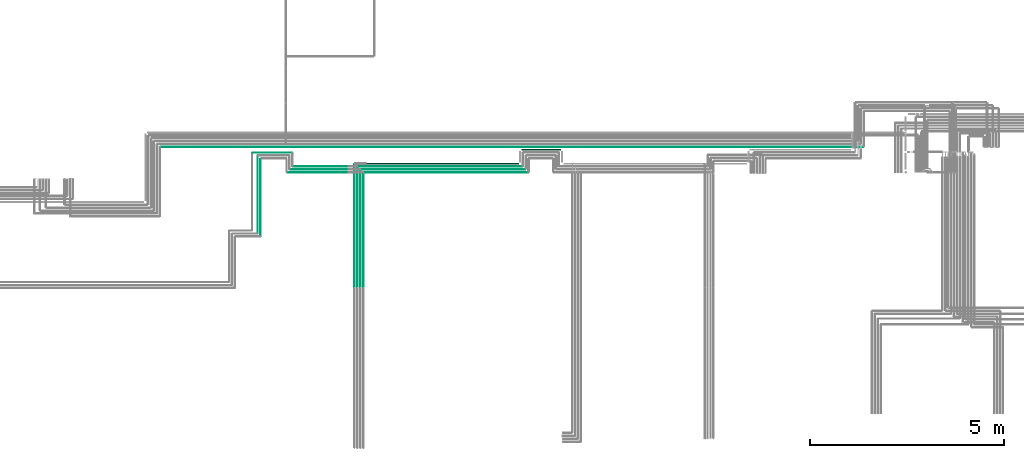
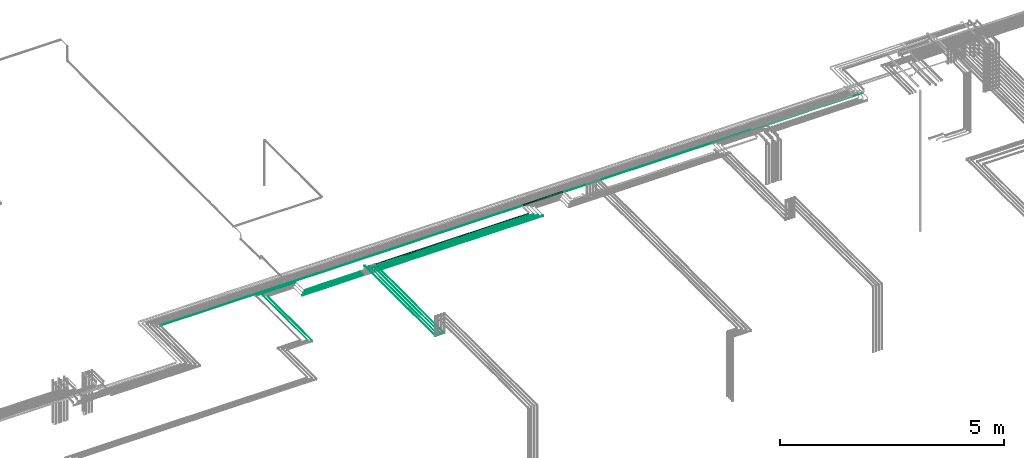
# One storey, part 11 of 65: 16 flow segments.
"""IFC2X3 building model written with IfcOpenShell, lengths in millimetres."""

from ifc_helpers import new_model, entity, si_unit, converted_unit, derived_unit, direction, frame, frame_2d, origin, origin_2d_with_axis, place, context, subcontext, project, spatial, circle, extrude, type_object, element, save


model = new_model("IFC2X3")

# Units and contexts
model_context = context("Model", 3, precision=0.01, world=origin(), true_north=direction((6.12303176911189e-17, 1.0)))
body_context = subcontext(model_context, "Body", "Model", "MODEL_VIEW")
ifc_project = project(units=[si_unit("LENGTHUNIT", "METRE", prefix="MILLI"), si_unit("AREAUNIT", "SQUARE_METRE"), si_unit("VOLUMEUNIT", "CUBIC_METRE"), converted_unit("PLANEANGLEUNIT", "DEGREE", entity("IfcRatioMeasure", 0.0174532925199433), si_unit("PLANEANGLEUNIT", "RADIAN"), dimensions=[0, 0, 0, 0, 0, 0, 0]), si_unit("MASSUNIT", "GRAM", prefix="KILO"), derived_unit("MASSDENSITYUNIT", [(si_unit("MASSUNIT", "GRAM", prefix="KILO"), 1), (si_unit("LENGTHUNIT", "METRE"), -3)]), derived_unit("MOMENTOFINERTIAUNIT", [(si_unit("LENGTHUNIT", "METRE"), 4)]), si_unit("TIMEUNIT", "SECOND"), si_unit("FREQUENCYUNIT", "HERTZ"), si_unit("THERMODYNAMICTEMPERATUREUNIT", "DEGREE_CELSIUS"), derived_unit("THERMALTRANSMITTANCEUNIT", [(si_unit("MASSUNIT", "GRAM", prefix="KILO"), 1), (si_unit("THERMODYNAMICTEMPERATUREUNIT", "KELVIN"), -1), (si_unit("TIMEUNIT", "SECOND"), -3)]), derived_unit("VOLUMETRICFLOWRATEUNIT", [(si_unit("LENGTHUNIT", "METRE"), 3), (si_unit("TIMEUNIT", "SECOND"), -1)]), derived_unit("MASSFLOWRATEUNIT", [(si_unit("MASSUNIT", "GRAM", prefix="KILO"), 1), (si_unit("TIMEUNIT", "SECOND"), -1)]), derived_unit("ROTATIONALFREQUENCYUNIT", [(si_unit("TIMEUNIT", "SECOND"), -1)]), si_unit("ELECTRICCURRENTUNIT", "AMPERE"), si_unit("ELECTRICVOLTAGEUNIT", "VOLT"), si_unit("POWERUNIT", "WATT"), si_unit("FORCEUNIT", "NEWTON", prefix="KILO"), si_unit("ILLUMINANCEUNIT", "LUX"), si_unit("LUMINOUSFLUXUNIT", "LUMEN"), si_unit("LUMINOUSINTENSITYUNIT", "CANDELA"), derived_unit("USERDEFINED", [(si_unit("MASSUNIT", "GRAM", prefix="KILO"), -1), (si_unit("LENGTHUNIT", "METRE"), -2), (si_unit("TIMEUNIT", "SECOND"), 3), (si_unit("LUMINOUSFLUXUNIT", "LUMEN"), 1)]), derived_unit("LINEARVELOCITYUNIT", [(si_unit("LENGTHUNIT", "METRE"), 1), (si_unit("TIMEUNIT", "SECOND"), -1)]), si_unit("PRESSUREUNIT", "PASCAL"), derived_unit("USERDEFINED", [(si_unit("LENGTHUNIT", "METRE"), -2), (si_unit("MASSUNIT", "GRAM", prefix="KILO"), 1), (si_unit("TIMEUNIT", "SECOND"), -2)]), derived_unit("LINEARFORCEUNIT", [(si_unit("MASSUNIT", "GRAM", prefix="KILO"), 1), (si_unit("LENGTHUNIT", "METRE"), 1), (si_unit("TIMEUNIT", "SECOND"), -2), (si_unit("LENGTHUNIT", "METRE"), -1)]), derived_unit("PLANARFORCEUNIT", [(si_unit("MASSUNIT", "GRAM", prefix="KILO"), 1), (si_unit("LENGTHUNIT", "METRE"), 1), (si_unit("TIMEUNIT", "SECOND"), -2), (si_unit("LENGTHUNIT", "METRE"), -2)])], contexts=[model_context])

# Site, building, storey
site_placement = place(None, frame((0.0, -0.00077364408347762, 0.0)))
site = spatial("IfcSite", under=ifc_project, at=site_placement, CompositionType="ELEMENT")
building_placement = place(site_placement, origin())
building = spatial("IfcBuilding", under=site, at=building_placement, CompositionType="ELEMENT")
storey_placement = place(building_placement, frame((0.0, 0.0, 19800.0)))
storey = spatial("IfcBuildingStorey", under=building, at=storey_placement, CompositionType="ELEMENT", Elevation=19800.0)

# Flow segments
pipe_segment_type = type_object("IfcPipeSegmentType", PredefinedType="NOTDEFINED")
flow_segment_1_placement = place(storey_placement, frame((55175.7164041243, 8230.90493375775, 2530.90472776409)))
element("IfcFlowSegment", 1, at=flow_segment_1_placement, inside=storey, type_object=pipe_segment_type, context=body_context, shape_type="SweptSolid", body=[
    extrude(circle(Radius=17.5, at=frame_2d((1.08286712929839e-12, 0.0), x_axis=(1.0, 0.0))), frame((0.0, 19.0952722359173, 19.0952722359163), z_axis=(1.0, 0.0, 0.0), x_axis=(0.0, 1.0, 0.0)), (0.0, 0.0, 1.0), 1004.28425505536),
])
flow_segment_2_placement = place(storey_placement, frame((50935.3052438068, 4710.0, 2619.40472776409)))
element("IfcFlowSegment", 2, at=flow_segment_2_placement, inside=storey, type_object=pipe_segment_type, context=body_context, shape_type="SweptSolid", body=[
    extrude(circle(Radius=4.0, at=origin_2d_with_axis()), frame((5.59527223591499, 0.0, 5.59527223591499), z_axis=(0.0, 1.0, 0.0), x_axis=(-1.0, 0.0, 0.0)), (0.0, 0.0, 1.0), 3094.99999999999),
])
flow_segment_3_placement = place(storey_placement, frame((51008.3052438068, 4714.0, 2617.4047277641)))
element("IfcFlowSegment", 3, at=flow_segment_3_placement, inside=storey, type_object=pipe_segment_type, context=body_context, shape_type="SweptSolid", body=[
    extrude(circle(Radius=6.0, at=frame_2d((-8.66293703438714e-12, 0.0), x_axis=(1.0, 0.0))), frame((7.59527223591454, 0.0, 7.59527223591454), z_axis=(0.0, 1.0, 0.0), x_axis=(-1.0, 0.0, 0.0)), (0.0, 0.0, 1.0), 3011.99999999999),
])
flow_segment_4_placement = place(storey_placement, frame((51083.3052438068, 4714.0, 2617.4047277641)))
element("IfcFlowSegment", 4, at=flow_segment_4_placement, inside=storey, type_object=pipe_segment_type, context=body_context, shape_type="SweptSolid", body=[
    extrude(circle(Radius=6.0, at=origin_2d_with_axis()), frame((7.59527223591454, 0.0, 7.59527223591454), z_axis=(0.0, 1.0, 0.0), x_axis=(-1.0, 0.0, 0.0)), (0.0, 0.0, 1.0), 2936.99999999999),
])
flow_segment_5_placement = place(storey_placement, frame((50856.8052438068, 4718.0, 2615.9047277641)))
element("IfcFlowSegment", 5, at=flow_segment_5_placement, inside=storey, type_object=pipe_segment_type, context=body_context, shape_type="SweptSolid", body=[
    extrude(circle(Radius=7.5, at=frame_2d((8.66293703438714e-12, 0.0), x_axis=(1.0, 0.0))), frame((9.09527223593152, 0.0, 9.09527223591419), z_axis=(0.0, 1.0, 0.0), x_axis=(-1.0, 0.0, 0.0)), (0.0, 0.0, 1.0), 3154.00000000005),
])
flow_segment_6_placement = place(storey_placement, frame((49138.0006591797, 7657.40472776409, 2542.40472776409)))
element("IfcFlowSegment", 6, at=flow_segment_6_placement, inside=storey, type_object=pipe_segment_type, context=body_context, shape_type="SweptSolid", body=[
    extrude(circle(Radius=6.0, at=frame_2d((-1.62430069394759e-11, 0.0), x_axis=(1.0, 0.0))), frame((0.0, 7.59527223593294, 7.59527223591454), z_axis=(1.0, 0.0, 0.0), x_axis=(0.0, 1.0, 0.0)), (0.0, 0.0, 1.0), 1569.7954113377),
])
flow_segment_7_placement = place(storey_placement, frame((49207.0006591797, 7734.40472776409, 2544.40472776409)))
element("IfcFlowSegment", 7, at=flow_segment_7_placement, inside=storey, type_object=pipe_segment_type, context=body_context, shape_type="SweptSolid", body=[
    extrude(circle(Radius=4.0, at=frame_2d((-2.92374124910566e-11, 0.0), x_axis=(1.0, 0.0))), frame((0.0, 5.59527223594531, 5.59527223591499), z_axis=(1.0, 0.0, 0.0), x_axis=(0.0, 1.0, 0.0)), (0.0, 0.0, 1.0), 1503.82807953106),
])
flow_segment_8_placement = place(storey_placement, frame((49282.0006591797, 7809.40472776409, 2544.40472776409)))
element("IfcFlowSegment", 8, at=flow_segment_8_placement, inside=storey, type_object=pipe_segment_type, context=body_context, shape_type="SweptSolid", body=[
    extrude(circle(Radius=4.0, at=frame_2d((-3.14031467496534e-11, 0.0), x_axis=(1.0, 0.0))), frame((0.0, 5.59527223594748, 5.59527223591499), z_axis=(1.0, 0.0, 0.0), x_axis=(0.0, 1.0, 0.0)), (0.0, 0.0, 1.0), 1431.85604152656),
])
flow_segment_9_placement = place(storey_placement, frame((50947.9005160427, 7807.40472776408, 2542.40472776409)))
element("IfcFlowSegment", 9, at=flow_segment_9_placement, inside=storey, type_object=pipe_segment_type, context=body_context, shape_type="SweptSolid", body=[
    extrude(circle(Radius=6.0, at=frame_2d((1.08286712929839e-12, 0.0), x_axis=(1.0, 0.0))), frame((0.0, 7.5952722359167, 7.59527223591454), z_axis=(1.0, 0.0, 0.0), x_axis=(0.0, 1.0, 0.0)), (0.0, 0.0, 1.0), 4248.81588808166),
])
flow_segment_10_placement = place(storey_placement, frame((51023.9005160427, 7730.90472776408, 2540.90472776409)))
element("IfcFlowSegment", 10, at=flow_segment_10_placement, inside=storey, type_object=pipe_segment_type, context=body_context, shape_type="SweptSolid", body=[
    extrude(circle(Radius=7.5, at=frame_2d((1.08286712929839e-12, 0.0), x_axis=(1.0, 0.0))), frame((0.0, 9.09527223591744, 9.09527223591419), z_axis=(1.0, 0.0, 0.0), x_axis=(0.0, 1.0, 0.0)), (0.0, 0.0, 1.0), 4243.81588808168),
])
flow_segment_11_placement = place(storey_placement, frame((51098.9005160427, 7655.90472776409, 2540.90472776409)))
element("IfcFlowSegment", 11, at=flow_segment_11_placement, inside=storey, type_object=pipe_segment_type, context=body_context, shape_type="SweptSolid", body=[
    extrude(circle(Radius=7.5, at=frame_2d((1.08286712929839e-12, 0.0), x_axis=(1.0, 0.0))), frame((0.0, 9.09527223591744, 9.09527223591419), z_axis=(1.0, 0.0, 0.0), x_axis=(0.0, 1.0, 0.0)), (0.0, 0.0, 1.0), 4243.81588808164),
])
flow_segment_12_placement = place(storey_placement, frame((51171.7365525862, 7870.90472776409, 2530.90472776409)))
element("IfcFlowSegment", 12, at=flow_segment_12_placement, inside=storey, type_object=pipe_segment_type, context=body_context, shape_type="SweptSolid", body=[
    extrude(circle(Radius=17.5, at=origin_2d_with_axis()), frame((0.0, 19.0952722359834, 19.0952722359163), z_axis=(1.0, 0.0, 0.0), x_axis=(0.0, -1.0, 0.0)), (0.0, 0.0, 1.0), 3923.97985153818),
])
flow_segment_13_placement = place(storey_placement, frame((48242.7189676009, 8169.40493375778, 2544.40472776409)))
element("IfcFlowSegment", 13, at=flow_segment_13_placement, inside=storey, type_object=pipe_segment_type, context=body_context, shape_type="SweptSolid", body=[
    extrude(circle(Radius=4.0, at=frame_2d((1.08286712929839e-12, 0.0), x_axis=(1.0, 0.0))), frame((0.0, 5.59527223591607, 5.59527223591499), z_axis=(1.0, 0.0, 0.0), x_axis=(0.0, 1.0, 0.0)), (0.0, 0.0, 1.0), 1008.28169157879),
])
flow_segment_14_placement = place(storey_placement, frame((48433.123695365, 6024.0, 2542.40472776409)))
element("IfcFlowSegment", 14, at=flow_segment_14_placement, inside=storey, type_object=pipe_segment_type, context=body_context, shape_type="SweptSolid", body=[
    extrude(circle(Radius=6.0, at=origin_2d_with_axis()), frame((7.59527223591454, 0.0, 7.59527223591454), z_axis=(0.0, 1.0, 0.0), x_axis=(-1.0, 0.0, 0.0)), (0.0, 0.0, 1.0), 1987.00020599365),
])
flow_segment_15_placement = place(storey_placement, frame((48360.123695365, 6095.0, 2544.40472776409)))
element("IfcFlowSegment", 15, at=flow_segment_15_placement, inside=storey, type_object=pipe_segment_type, context=body_context, shape_type="SweptSolid", body=[
    extrude(circle(Radius=4.0, at=frame_2d((1.38606992550194e-10, 0.0), x_axis=(1.0, 0.0))), frame((5.5952722360536, 0.0, 5.59527223591499), z_axis=(0.0, 1.0, 0.0), x_axis=(-1.0, 0.0, 0.0)), (0.0, 0.0, 1.0), 1995.00020599365),
])
flow_segment_16_placement = place(storey_placement, frame((45859.1221386505, 8317.40493375772, 2467.40472776413)))
element("IfcFlowSegment", 16, at=flow_segment_16_placement, inside=storey, type_object=pipe_segment_type, context=body_context, shape_type="SweptSolid", body=[
    extrude(circle(Radius=6.0, at=frame_2d((-3.89832166547421e-11, 0.0), x_axis=(1.0, 0.0))), frame((0.0, 7.59527223595352, 7.59527223591454), z_axis=(1.0, 0.0, 0.0), x_axis=(0.0, 1.0, 0.0)), (0.0, 0.0, 1.0), 18136.9372055938),
])

save(model, "model.ifc")
